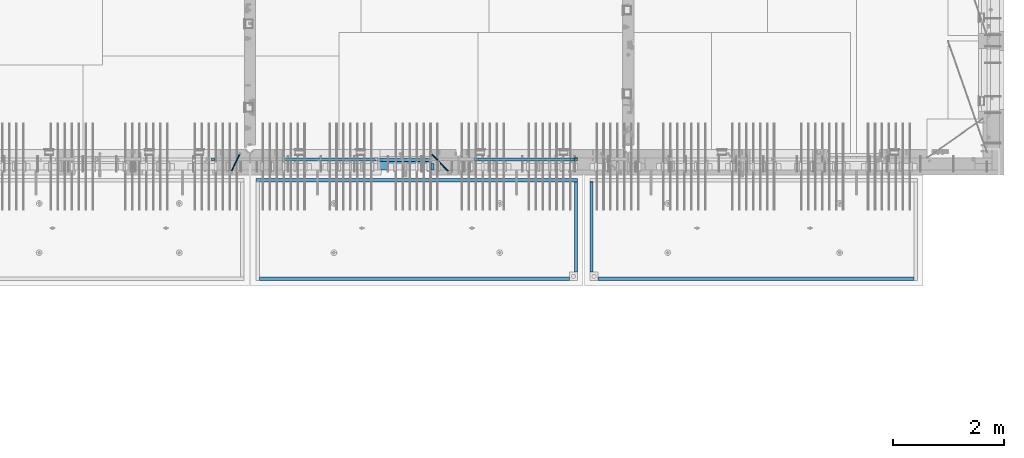
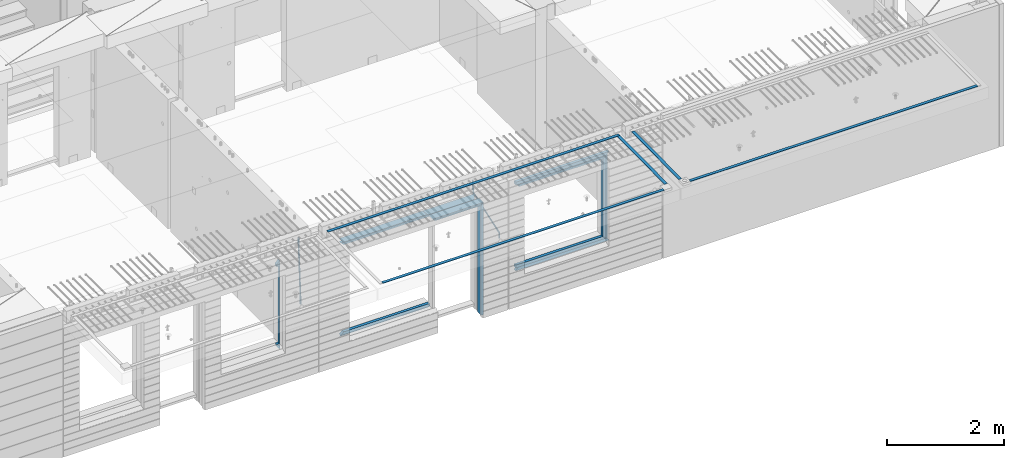
# One storey, part 91 of 334: 22 beams, 5 elements without a shape of their own.
"""IFC2X3 building model written with IfcOpenShell, lengths in millimetres."""

import ifcopenshell
import ifcopenshell.guid

model = None  # the IFC model being written
_history = None  # IfcOwnerHistory: only IFC2X3 demands one
_inside = {}  # id of a spatial element -> (the spatial element, [elements in it])
_under = {}  # id of a project, library or spatial element -> (it, [spatial elements below it])
_declared = {}  # id of a project -> (the project, [libraries it declares])
_typed = {}  # id of a type object -> (the type object, [elements of that type])
_made_of = {}  # id of a material, layer set ... -> (it, [elements and type objects made of it])


def new_model(schema):
    """Start an empty IFC model of exactly this schema.

    Asked for "IFC4X3", IfcOpenShell would pick the latest addendum, in which some entities
    have other attributes; the version numbers below select the first issue.
    IFC2X3 requires an IfcOwnerHistory on every rooted entity: one is made here for all.
    """
    global model, _history
    if schema == "IFC4X3":
        model = ifcopenshell.file(schema_version=(4, 3, 0, 0))
    else:
        model = ifcopenshell.file(schema=schema)
    _inside.clear()
    _under.clear()
    _declared.clear()
    _typed.clear()
    _made_of.clear()
    _history = None
    if model.schema == "IFC2X3":
        org = make("IfcOrganization", Name="unknown")
        user = make(
            "IfcPersonAndOrganization",
            ThePerson=make("IfcPerson", FamilyName="unknown"),
            TheOrganization=org,
        )
        app = make(
            "IfcApplication",
            ApplicationDeveloper=org,
            Version="unknown",
            ApplicationFullName="unknown",
            ApplicationIdentifier="unknown",
        )
        _history = make(
            "IfcOwnerHistory",
            OwningUser=user,
            OwningApplication=app,
            ChangeAction="ADDED",
            CreationDate=0,
        )
    return model


def make(cls, **values):
    """One entity of the class cls with the attributes given. An attribute that is None is left unset."""
    return model.create_entity(
        cls, **{name: value for name, value in values.items() if value is not None}
    )


def rooted(cls, **values):
    """An entity with a GlobalId (a new one), such as an element, a storey or a relation."""
    return make(cls, GlobalId=ifcopenshell.guid.new(), OwnerHistory=_history, **values)


def si_unit(unit_type, name, prefix=None):
    """IfcSIUnit, for example si_unit("LENGTHUNIT", "METRE", prefix="MILLI")."""
    return make("IfcSIUnit", UnitType=unit_type, Prefix=prefix, Name=name)


def assignment(units):
    """IfcUnitAssignment: the units of a project."""
    return None if units is None else make("IfcUnitAssignment", Units=units)


def point(xyz):
    """IfcCartesianPoint."""
    return None if xyz is None else make("IfcCartesianPoint", Coordinates=xyz)


def direction(xyz):
    """IfcDirection."""
    return None if xyz is None else make("IfcDirection", DirectionRatios=xyz)


def frame(location, z_axis=None, x_axis=None):
    """IfcAxis2Placement3D, a coordinate frame: its origin and axes. An axis left out is left unset."""
    return make(
        "IfcAxis2Placement3D",
        Location=point(location),
        Axis=direction(z_axis),
        RefDirection=direction(x_axis),
    )


def origin_with_axes():
    """The frame at (0, 0, 0) with the z axis (0, 0, 1) and the x axis (1, 0, 0) written out."""
    return frame((0.0, 0.0, 0.0), z_axis=(0.0, 0.0, 1.0), x_axis=(1.0, 0.0, 0.0))


def place(relative_to, where):
    """IfcLocalPlacement: puts the frame where relative to a parent placement (None: the world)."""
    return make(
        "IfcLocalPlacement", PlacementRelTo=relative_to, RelativePlacement=where
    )


def context(
    kind, dimensions, precision=None, world=None, true_north=None, identifier=None
):
    """IfcGeometricRepresentationContext, for example the 3D "Model" context."""
    return make(
        "IfcGeometricRepresentationContext",
        ContextIdentifier=identifier,
        ContextType=kind,
        CoordinateSpaceDimension=dimensions,
        Precision=precision,
        WorldCoordinateSystem=world,
        TrueNorth=true_north,
    )


def subcontext(parent, identifier, kind, view, scale=None):
    """IfcGeometricRepresentationSubContext, for example "Body" below "Model"."""
    return make(
        "IfcGeometricRepresentationSubContext",
        ContextIdentifier=identifier,
        ContextType=kind,
        ParentContext=parent,
        TargetScale=scale,
        TargetView=view,
    )


def project(units=None, contexts=None):
    """IfcProject with its units and contexts."""
    return rooted(
        "IfcProject",
        Name="project",
        RepresentationContexts=contexts,
        UnitsInContext=assignment(units),
    )


def spatial(cls, under=None, at=None, **own):
    """A site, building, storey or space (cls), placed at a placement, below another one or the project."""
    s = rooted(cls, ObjectPlacement=at, **own)
    if under is not None:
        _under.setdefault(under.id(), (under, []))[1].append(s)
    return s


def faces_of(points, faces, orient=None, outer=None):
    """IfcFace entities. A face is a list of loops; a loop is a list of indices into points, from 0.

    orient and outer hold one flag for each loop. By default every Orientation is true, the
    first loop of a face is its IfcFaceOuterBound and the others are IfcFaceBound.
    """
    made = []
    for i, loops in enumerate(faces):
        bounds = []
        for j, loop in enumerate(loops):
            is_outer = j == 0 if outer is None else outer[i][j]
            bounds.append(
                make(
                    "IfcFaceOuterBound" if is_outer else "IfcFaceBound",
                    Bound=make("IfcPolyLoop", Polygon=[points[k] for k in loop]),
                    Orientation=True if orient is None else orient[i][j],
                )
            )
        made.append(make("IfcFace", Bounds=bounds))
    return made


def faceted_brep(points, faces, orient=None, outer=None, voids=None):
    """IfcFacetedBrep: a solid bounded by flat faces; with voids (closed shells), ...WithVoids."""
    shared = [point(p) for p in points]
    hull = make("IfcClosedShell", CfsFaces=faces_of(shared, faces, orient, outer))
    if voids is None:
        return make("IfcFacetedBrep", Outer=hull)
    return make(
        "IfcFacetedBrepWithVoids",
        Outer=hull,
        Voids=[
            make(cls, CfsFaces=faces_of(shared, fs, o, b)) for cls, fs, o, b in voids
        ],
    )


def shape(context_of_items, identifier, shape_type, items):
    """IfcShapeRepresentation: the items that make up one representation, for example the "Body"."""
    return make(
        "IfcShapeRepresentation",
        ContextOfItems=context_of_items,
        RepresentationIdentifier=identifier,
        RepresentationType=shape_type,
        Items=items,
    )


def material(Name=None, Category=None):
    """IfcMaterial."""
    return make("IfcMaterial", Name=Name, Category=Category)


def made_of(thing, what):
    """Note that an element or type object is made of a material, layer set ...; save() writes the relation."""
    if what is not None:
        _made_of.setdefault(what.id(), (what, []))[1].append(thing)
    return thing


def type_object(cls, material=None, **own):
    """A type object (cls), such as IfcWallType, which elements share."""
    return made_of(rooted(cls, **own), material)


def element(
    cls,
    number,
    at=None,
    inside=None,
    cuts=None,
    type_object=None,
    material=None,
    context=None,
    identifier="Body",
    shape_type=None,
    held_by="IfcProductDefinitionShape",
    body=None,
    shapes=None,
    **own,
):
    """One element of the class cls, such as IfcWall. Its Tag is "e" and its number.

    at: its placement. inside: the storey or other place that contains it. cuts: it is an
    opening in that element (IfcRelVoidsElement). A single representation is given by context,
    identifier, shape_type and body (its items); several are given by shapes. held_by: the class
    of the entity that holds the representations. save() writes the other relations.
    """
    e = rooted(cls, Tag="e%d" % number, ObjectPlacement=at, **own)
    if body is not None:
        shapes = [shape(context, identifier, shape_type, body)]
    if shapes is not None:
        e.Representation = make(held_by, Representations=shapes)
    if inside is not None:
        _inside.setdefault(inside.id(), (inside, []))[1].append(e)
    if cuts is not None:
        rooted(
            "IfcRelVoidsElement", RelatingBuildingElement=cuts, RelatedOpeningElement=e
        )
    if type_object is not None:
        _typed.setdefault(type_object.id(), (type_object, []))[1].append(e)
    return made_of(e, material)


def aggregate(whole, parts):
    """IfcRelAggregates: a whole, such as a stair, and the parts it consists of."""
    return rooted("IfcRelAggregates", RelatingObject=whole, RelatedObjects=parts)


def save(model, path):
    """Write the relations noted so far, then the file.

    IfcRelAggregates (storeys below a building ...), IfcRelContainedInSpatialStructure (elements
    in a storey), IfcRelDefinesByType, IfcRelAssociatesMaterial and IfcRelDeclares: one each for
    every whole, place, type object, material and project.
    """
    for whole, parts in _under.values():
        aggregate(whole, parts)
    for where, things in _inside.values():
        rooted(
            "IfcRelContainedInSpatialStructure",
            RelatedElements=things,
            RelatingStructure=where,
        )
    for kind, things in _typed.values():
        rooted("IfcRelDefinesByType", RelatedObjects=things, RelatingType=kind)
    for what, things in _made_of.values():
        rooted("IfcRelAssociatesMaterial", RelatedObjects=things, RelatingMaterial=what)
    for by, libraries in _declared.values():
        rooted("IfcRelDeclares", RelatingContext=by, RelatedDefinitions=libraries)
    model.write(path)


model = new_model("IFC2X3")

# Units and contexts
model_context = context("Model", 3, precision=1e-05, world=origin_with_axes())
body_context = subcontext(model_context, "Body", "Model", "MODEL_VIEW")
ifc_project = project(units=[si_unit("LENGTHUNIT", "METRE", prefix="MILLI"), si_unit("AREAUNIT", "SQUARE_METRE"), si_unit("VOLUMEUNIT", "CUBIC_METRE"), si_unit("MASSUNIT", "GRAM", prefix="KILO"), si_unit("TIMEUNIT", "SECOND"), si_unit("PLANEANGLEUNIT", "RADIAN"), si_unit("SOLIDANGLEUNIT", "STERADIAN"), si_unit("THERMODYNAMICTEMPERATUREUNIT", "DEGREE_CELSIUS"), si_unit("LUMINOUSINTENSITYUNIT", "LUMEN")], contexts=[model_context])

# Site, building, storey
site_placement = place(None, origin_with_axes())
site = spatial("IfcSite", under=ifc_project, at=site_placement, CompositionType="ELEMENT")
building_placement = place(site_placement, origin_with_axes())
building = spatial("IfcBuilding", under=site, at=building_placement, CompositionType="ELEMENT")
storey_placement = place(building_placement, origin_with_axes())
storey = spatial("IfcBuildingStorey", under=building, at=storey_placement, Name="3", CompositionType="ELEMENT", Elevation=0.0)

# Assembly, beams
assembly_1_placement = place(storey_placement, origin_with_axes())
assembly_1 = element("IfcElementAssembly", 1, at=assembly_1_placement, inside=storey, AssemblyPlace="NOTDEFINED", PredefinedType="REINFORCEMENT_UNIT")
ifc_material_1 = material(Name="CONCRETE/C35/45")
beam_type_1 = type_object("IfcBeamType", PredefinedType="NOTDEFINED")
beam_1_placement = place(assembly_1_placement, frame((24034.9998642727, 7815.0, 90140.0), z_axis=(0.0, 0.0, -1.0), x_axis=(1.0, 0.0, 0.0)))
beam_1 = element("IfcBeam", 2, at=beam_1_placement, type_object=beam_type_1, material=ifc_material_1, Name="SK", context=body_context, shape_type="Brep", body=[
    faceted_brep([(70.0000000000164, -35.0, 35.0), (70.0000000000164, 35.0, 35.0), (0.0, -35.0, -35.0), (1039.99961853026, -35.0, -35.0), (980.889062997325, -35.0, 35.0), (980.889062997325, 35.0, 35.0)], [[[0, 1, 2]], [[0, 2, 3, 4]], [[1, 0, 4, 5]], [[2, 1, 5, 3]], [[4, 3, 5]]]),
])
ifc_material_2 = material(Name="TIMBER")
beam_type_2 = type_object("IfcBeamType", Name="50X150", PredefinedType="NOTDEFINED")
beam_2_placement = place(assembly_1_placement, frame((24104.9998642727, 7705.0, 90080.0), z_axis=(0.0, 0.0, -1.0), x_axis=(1.0, 0.0, 0.0)))
beam_2 = element("IfcBeam", 3, at=beam_2_placement, type_object=beam_type_2, material=ifc_material_2, ObjectType="50X150", context=body_context, shape_type="Brep", body=[
    faceted_brep([(50.0000000000036, -75.0, 25.0), (50.0000000000036, 75.0, 25.0), (0.0, 75.0, -25.0), (0.0, -75.0, -25.0), (1009.99961853027, -75.0, -25.0), (959.999618530259, -75.0, 25.0), (959.999618530259, 75.0, 25.0), (1009.99961853027, 75.0, -25.0)], [[[0, 1, 2, 3]], [[0, 3, 4, 5]], [[1, 0, 5, 6]], [[2, 1, 6, 7]], [[3, 2, 7, 4]], [[6, 5, 4, 7]]]),
])

# Assembly, beam
assembly_2_placement = place(storey_placement, origin_with_axes())
assembly_2 = element("IfcElementAssembly", 4, at=assembly_2_placement, inside=storey, AssemblyPlace="NOTDEFINED", PredefinedType="REINFORCEMENT_UNIT")
ifc_material_3 = material()
beam_type_3 = type_object("IfcBeamType", Name="D20", PredefinedType="NOTDEFINED")
beam_3_placement = place(assembly_2_placement, frame((21625.0073331492, 7924.99999997881, 90407.5), z_axis=(-0.000415599999849952, -0.999999913638316, 0.0), x_axis=(-6.05680000062309e-05, -4.00000390151988e-09, -0.999999998165759)))
beam_3 = element("IfcBeam", 5, at=beam_3_placement, type_object=beam_type_3, material=ifc_material_3, Name="JM20", ObjectType="D20", context=body_context, shape_type="Brep", body=[
    faceted_brep([(-0.00060564729210455, -9.99999998165731, 0.0), (-0.000428079845733009, -7.07106779890455, -7.07106781186667), (119.575515501536, -7.07830994756296, -7.07106481604933), (119.575337932896, -10.0072421307195, -3.43332612828817e-06), (0.0, 0.0, -10.0), (119.575943836026, -0.00724214867295814, -9.99999700418266), (0.00042843479604926, 7.07106779888636, -7.07106781186303), (119.57637202373, 7.06382565022977, -7.07106481604933), (0.00060564729210455, 9.99999998166459, 3.63797880709171e-12), (119.576549238118, 9.99275783300072, 2.99581552098971e-06), (0.000428079845733009, 7.07106779890819, 7.07106781186667), (119.576371669405, 7.06382565024978, 7.07107080768037), (0.0, 0.0, 10.0), (119.57594333493, -0.00724214864203532, 10.0000029958155), (-0.000428434810601175, -7.07106779888272, 7.07106781186667), (119.575515147211, -7.07830994754295, 7.07107080768037), (123.006973508192, -7.07825951346604, -6.96785036235087), (122.582196132164, -10.0072047447829, 0.090452766209637), (123.182421564867, -0.00718632049392909, -9.89150999405319), (123.005765870272, 7.06387605862983, -6.9678969281922), (122.5804889344, 9.99279518261392, 0.090375952400791), (122.155712218591, 7.06384995171538, 7.14866812117907), (121.980264161975, -0.00722324126036256, 10.0723277528814), (122.156919856599, -7.07828562038412, 7.14871468701676), (235.904703171851, -7.06860422895625, -0.169508357435916), (235.479926262604, -9.99754169577864, 6.88878701985595), (236.080151695453, 0.002465748351824, -3.09317573838871), (235.903496467319, 7.07353134315781, -0.16957042179456), (235.478219724217, 10.0024582304504, 6.88869924890878), (235.053442814489, 7.07352076285679, 13.9469946275131), (234.877994290917, 0.00245078554871725, 16.8706620084649), (235.05464951905, -7.06861480925727, 13.9470566918726), (247.69730842374, 6.49890140729985, 1.5904257279044), (247.708271375333, -0.564091162203113, -1.35790592567901), (246.351191555892, -7.5775885142175, 1.3894260566567), (244.421027918448, -10.4331790195793, 8.22307186000126), (243.04844414418, -7.45809648886643, 15.1399744532118), (243.037481192529, -0.395103919359826, 18.0883061067871), (244.394561011999, 6.61839343264, 15.3409741244495), (246.324724649443, 9.47398393802723, 8.50732832109588), (256.620302657771, 7.90789673379186, 11.9850227549905), (258.892076862918, 4.79603600307382, 5.371853429986), (253.26121545503, 5.26966351612282, 18.3359992487194), (250.782522980895, -1.57322241172369, 20.7044670154446), (250.636209669712, -8.61229127897968, 17.7030097594688), (252.907983874131, -11.724152010418, 11.0898404357176), (256.267071077629, -9.08591879203959, 4.7388639407518), (258.745763551793, -2.24303286420036, 2.37039617402661), (1008.47908473376, -166.485147783689, 337.205828025195), (1005.11999753102, -169.123381001344, 343.556804518913), (1010.95777720789, -159.642261855857, 334.837360258474), (1011.10409051905, -152.60319298859, 337.838817514449), (1008.83231631388, -149.491332257865, 344.451986839456), (1005.47322911114, -152.129565475519, 350.802963333173), (1002.99453663701, -158.972451403351, 353.171431099895), (1002.84822332587, -166.011520270618, 350.169973843918), (1010.17087503639, -166.839152352099, 337.953575170377), (1008.40147312843, -169.810024819315, 345.007169854448), (1011.47638800017, -159.75078038171, 335.066578819891), (1011.55326023143, -152.697181073247, 338.037344110582), (1010.35646101969, -149.810257238067, 345.125637025791), (1008.58705911171, -152.781129705283, 352.179231709861), (1007.28154614793, -159.869501675676, 355.066228060347), (1007.20467391667, -166.923100984135, 352.095462769656), (1012.05411677422, -166.839038287919, 337.953575122971), (1012.05429688386, -169.809803575103, 345.007169762499), (1012.05368737834, -159.750745415844, 335.066578805359), (1012.05326023052, -152.697150789249, 338.037344097996), (1012.05308554815, -149.81015447692, 345.125636983083), (1012.05326565779, -152.780919764096, 352.179231622609), (1012.05369505366, -159.869212636178, 355.066227940223), (1012.05412220149, -166.92280726277, 352.095462647586), (1117.510115663, -166.832651029355, 337.953572468433), (1117.51029577265, -169.803416316539, 345.00716710796), (1117.50968626713, -159.744358157277, 335.06657615082), (1117.50925911931, -152.690763530685, 338.037341443456), (1117.50908443694, -149.803767218353, 345.125634328543), (1117.50926454658, -152.774532505533, 352.17922896807), (1117.50969394245, -159.862825377615, 355.066225285684), (1117.51012109026, -166.916420004207, 352.095459993046)], [[[0, 1, 2, 3]], [[1, 4, 5, 2]], [[4, 6, 7, 5]], [[6, 8, 9, 7]], [[8, 10, 11, 9]], [[10, 12, 13, 11]], [[12, 14, 15, 13]], [[14, 0, 3, 15]], [[14, 12, 10, 8, 6, 4, 1, 0]], [[3, 2, 16, 17]], [[2, 5, 18, 16]], [[5, 7, 19, 18]], [[7, 9, 20, 19]], [[9, 11, 21, 20]], [[11, 13, 22, 21]], [[13, 15, 23, 22]], [[15, 3, 17, 23]], [[17, 16, 24, 25]], [[16, 18, 26, 24]], [[18, 19, 27, 26]], [[19, 20, 28, 27]], [[20, 21, 29, 28]], [[21, 22, 30, 29]], [[22, 23, 31, 30]], [[23, 17, 25, 31]], [[26, 27, 32, 33]], [[24, 26, 33, 34]], [[25, 24, 34, 35]], [[31, 25, 35, 36]], [[30, 31, 36, 37]], [[29, 30, 37, 38]], [[28, 29, 38, 39]], [[27, 28, 39, 32]], [[39, 40, 41, 32]], [[38, 42, 40, 39]], [[37, 43, 42, 38]], [[36, 44, 43, 37]], [[35, 45, 44, 36]], [[34, 46, 45, 35]], [[33, 47, 46, 34]], [[32, 41, 47, 33]], [[45, 46, 48, 49]], [[46, 47, 50, 48]], [[47, 41, 51, 50]], [[41, 40, 52, 51]], [[40, 42, 53, 52]], [[42, 43, 54, 53]], [[43, 44, 55, 54]], [[44, 45, 49, 55]], [[49, 48, 56, 57]], [[48, 50, 58, 56]], [[50, 51, 59, 58]], [[51, 52, 60, 59]], [[52, 53, 61, 60]], [[53, 54, 62, 61]], [[54, 55, 63, 62]], [[55, 49, 57, 63]], [[57, 56, 64, 65]], [[56, 58, 66, 64]], [[58, 59, 67, 66]], [[59, 60, 68, 67]], [[60, 61, 69, 68]], [[61, 62, 70, 69]], [[62, 63, 71, 70]], [[63, 57, 65, 71]], [[65, 64, 72, 73]], [[64, 66, 74, 72]], [[66, 67, 75, 74]], [[67, 68, 76, 75]], [[68, 69, 77, 76]], [[69, 70, 78, 77]], [[70, 71, 79, 78]], [[71, 65, 73, 79]], [[74, 75, 76, 77, 78, 79, 73, 72]]]),
])

# Beam
beam_4_placement = place(assembly_1_placement, frame((25075.0293329014, 7924.99999993642, 90407.5), z_axis=(-0.000415599999849952, -0.999999913638316, 0.0), x_axis=(-0.000242263999929879, 0.0, -0.999999970654077)))
beam_4 = element("IfcBeam", 6, at=beam_4_placement, type_object=beam_type_3, material=ifc_material_3, Name="JM20", ObjectType="D20", context=body_context, shape_type="Brep", body=[
    faceted_brep([(-0.00060564729210455, -9.99999998165731, 0.0), (-0.000428079845733009, -7.07106779890455, -7.07106781186667), (119.575515501536, -7.07830994756296, -7.07106481604933), (119.575337932896, -10.0072421307195, -3.43332612828817e-06), (0.0, 0.0, -10.0), (119.575943836026, -0.00724214867295814, -9.99999700418266), (0.00042843479604926, 7.07106779888636, -7.07106781186303), (119.57637202373, 7.06382565022977, -7.07106481604933), (0.00060564729210455, 9.99999998166459, 3.63797880709171e-12), (119.576549238118, 9.99275783300072, 2.99581552098971e-06), (0.000428079845733009, 7.07106779890819, 7.07106781186667), (119.576371669405, 7.06382565024978, 7.07107080768037), (0.0, 0.0, 10.0), (119.57594333493, -0.00724214864203532, 10.0000029958155), (-0.000428434810601175, -7.07106779888272, 7.07106781186667), (119.575515147211, -7.07830994754295, 7.07107080768037), (123.008274907785, -7.07795567963694, -6.96780325792497), (122.584029738471, -10.0069316327917, 0.0905081323508057), (123.182440752484, -0.00686994861462153, -9.89150922917906), (123.004503280346, 7.06417944043824, -6.96794247666548), (122.578695849254, 9.99306765562687, 0.0903112464729929), (122.15445067735, 7.0640917031651, 7.14862263591931), (121.980284832651, -0.0069940278553986, 10.072328607177), (122.158222304832, -7.07804341691372, 7.14876185467801), (233.088395941915, -7.04853267872386, -0.33914435535371), (232.664150764584, -9.97750862893736, 6.71916703474017), (233.262561786629, 0.0225530520438042, -3.26285032724809), (233.08462431423, 7.09360244138225, -0.339283575355694), (232.658816882788, 10.0224906572403, 6.71897014756632), (232.234571710651, 7.09351470543697, 13.777281537301), (232.060405865923, 0.0224289746693103, 16.7009875091953), (232.238343338337, -7.04862041468004, 13.7774207573038), (248.070459246126, -5.60737147376494, 1.85103242021069), (247.013897852143, -8.59717146491312, 8.81690765643543), (244.865343898215, -5.8339984379636, 15.6233189364948), (242.883391151001, 1.06351832306973, 18.2831628436061), (242.22904064988, 8.05490704629119, 15.2383388907911), (243.285602043848, 11.0447070374539, 8.27246365456904), (245.434155997835, 8.28153401051895, 1.46605237452331), (247.416108745019, 1.38401724946743, -1.19379153259433), (260.512945877912, 5.37327174938764, 3.16696371259513), (261.933955342625, -1.38459511741894, 6.46705632785779), (256.86166640259, 11.762316953962, 5.27098446848322), (253.118986913221, 14.0399244660766, 11.5466117722399), (251.477318295016, 10.8719026949148, 18.3176682617204), (252.898327759729, 4.11403582813364, 21.6177608769931), (256.54960723508, -2.27500937642981, 19.5137401211105), (260.292286730517, -4.55261688891915, 13.2381128181169), (1011.6899267952, 318.016952836686, 337.688913324002), (1010.04825817693, 314.848931065488, 344.459969813425), (1010.26891733034, 324.774819703332, 334.388820708672), (1006.61763785462, 331.163864907652, 336.492841464405), (1002.87495836492, 333.441472419578, 342.76846876801), (1001.23328974665, 330.273450648383, 349.539525257433), (1002.6542992115, 323.515583781733, 352.839617872763), (1006.30557868723, 317.12653857741, 350.73559711703), (1012.11607330808, 318.198494379605, 337.877173297548), (1011.23010097447, 315.352404773395, 344.982075913254), (1011.34812648257, 325.234570724882, 334.865586047124), (1009.37611333313, 332.338995712049, 337.711461129013), (1007.35521241752, 335.350093536494, 344.747723517063), (1006.46924008391, 332.504003930284, 351.85262613277), (1007.23718690944, 325.467927585003, 354.864213383194), (1009.20920005886, 318.363502597836, 352.018338301305), (1012.61607329341, 318.198615511596, 337.877173247205), (1012.61676345688, 315.352740711776, 344.982075773638), (1012.61436835937, 325.234877489685, 334.865585919631), (1012.61264738202, 332.339779807688, 337.71146080314), (1012.61191848651, 335.351367047057, 344.747722987787), (1012.61260864999, 332.505492247237, 351.852625514221), (1012.61431358402, 325.469230269144, 354.864212841793), (1012.61603456138, 318.364327951142, 352.018337958285), (1117.42297412557, 318.224006449098, 337.87716269464), (1117.42366428903, 315.378131649279, 344.982065221072), (1117.42126919153, 325.260268427191, 334.865575367066), (1117.41954821418, 332.365170745194, 337.711450250575), (1117.41881931867, 335.376757984559, 344.747712435222), (1117.41950948215, 332.530883184736, 351.852614961655), (1117.42121441617, 325.494621206646, 354.864202289227), (1117.42293539354, 318.389718888644, 352.018327405719)], [[[0, 1, 2, 3]], [[1, 4, 5, 2]], [[4, 6, 7, 5]], [[6, 8, 9, 7]], [[8, 10, 11, 9]], [[10, 12, 13, 11]], [[12, 14, 15, 13]], [[14, 0, 3, 15]], [[14, 12, 10, 8, 6, 4, 1, 0]], [[3, 2, 16, 17]], [[2, 5, 18, 16]], [[5, 7, 19, 18]], [[7, 9, 20, 19]], [[9, 11, 21, 20]], [[11, 13, 22, 21]], [[13, 15, 23, 22]], [[15, 3, 17, 23]], [[17, 16, 24, 25]], [[16, 18, 26, 24]], [[18, 19, 27, 26]], [[19, 20, 28, 27]], [[20, 21, 29, 28]], [[21, 22, 30, 29]], [[22, 23, 31, 30]], [[23, 17, 25, 31]], [[25, 24, 32, 33]], [[31, 25, 33, 34]], [[30, 31, 34, 35]], [[29, 30, 35, 36]], [[28, 29, 36, 37]], [[27, 28, 37, 38]], [[26, 27, 38, 39]], [[24, 26, 39, 32]], [[39, 40, 41, 32]], [[38, 42, 40, 39]], [[37, 43, 42, 38]], [[36, 44, 43, 37]], [[35, 45, 44, 36]], [[34, 46, 45, 35]], [[33, 47, 46, 34]], [[32, 41, 47, 33]], [[47, 41, 48, 49]], [[41, 40, 50, 48]], [[40, 42, 51, 50]], [[42, 43, 52, 51]], [[43, 44, 53, 52]], [[44, 45, 54, 53]], [[45, 46, 55, 54]], [[46, 47, 49, 55]], [[49, 48, 56, 57]], [[48, 50, 58, 56]], [[50, 51, 59, 58]], [[51, 52, 60, 59]], [[52, 53, 61, 60]], [[53, 54, 62, 61]], [[54, 55, 63, 62]], [[55, 49, 57, 63]], [[57, 56, 64, 65]], [[56, 58, 66, 64]], [[58, 59, 67, 66]], [[59, 60, 68, 67]], [[60, 61, 69, 68]], [[61, 62, 70, 69]], [[62, 63, 71, 70]], [[63, 57, 65, 71]], [[65, 64, 72, 73]], [[64, 66, 74, 72]], [[66, 67, 75, 74]], [[67, 68, 76, 75]], [[68, 69, 77, 76]], [[69, 70, 78, 77]], [[70, 71, 79, 78]], [[71, 65, 73, 79]], [[74, 75, 76, 77, 78, 79, 73, 72]]]),
])

# Assembly, beams
assembly_3_placement = place(storey_placement, origin_with_axes())
assembly_3 = element("IfcElementAssembly", 7, at=assembly_3_placement, inside=storey, AssemblyPlace="NOTDEFINED", PredefinedType="REINFORCEMENT_UNIT")
ifc_material_4 = material(Name="CONCRETE/Concrete_Undefined")
beam_type_4 = type_object("IfcBeamType", PredefinedType="NOTDEFINED")
beam_5_placement = place(assembly_3_placement, frame((27949.9413896323, 7420.0548526853, 90725.6636564041), z_axis=(3.20999999465459e-07, -0.00901957599816896, 0.999959322797038), x_axis=(3.55380000057318e-05, -0.999959322165559, -0.00901957600149657)))
beam_5 = element("IfcBeam", 8, at=beam_5_placement, type_object=beam_type_4, material=ifc_material_4, context=body_context, shape_type="Brep", body=[
    faceted_brep([(2.5465851649642e-11, 29.9999999999982, -4.99999999998545), (-2.91038304567337e-11, 29.9999999999982, 5.0), (1625.35189228369, 30.0000000000073, 5.0), (1625.35189228371, 30.0000000000073, -5.0), (-2.5465851649642e-11, -30.0000000000018, 5.0), (1625.35189228368, -29.9999999999927, 5.00000000001455), (2.72848410531878e-11, -30.0000000000018, -4.99999999998545), (1625.35189228371, -29.9999999999927, -4.99999999998545)], [[[0, 1, 2, 3]], [[1, 4, 5, 2]], [[4, 6, 7, 5]], [[6, 0, 3, 7]], [[5, 7, 3, 2]], [[6, 4, 1, 0]]]),
])
beam_6_placement = place(assembly_3_placement, frame((33750.1798578673, 5674.89208457699, 90711.2777998596), z_axis=(-0.00010875600001081, -1.00000033862182e-09, 0.999999994086066), x_axis=(-0.999999994070015, -5.66600000038745e-06, -0.000108756000006807)))
beam_6 = element("IfcBeam", 9, at=beam_6_placement, type_object=beam_type_4, material=ifc_material_4, context=body_context, shape_type="Brep", body=[
    faceted_brep([(2.5465851649642e-11, 29.9999999999982, -4.99999999998545), (-2.91038304567337e-11, 29.9999999999982, 5.0), (5682.56261276337, 30.0, 5.0), (5682.56261276337, 30.0, -5.0), (-2.5465851649642e-11, -30.0000000000018, 5.0), (5682.56261276337, -30.0, 5.0), (2.72848410531878e-11, -30.0000000000018, -4.99999999998545), (5682.56261276337, -30.0, -5.0)], [[[0, 1, 2, 3]], [[1, 4, 5, 2]], [[4, 6, 7, 5]], [[6, 0, 3, 7]], [[5, 7, 3, 2]], [[6, 4, 1, 0]]]),
])
aggregate(assembly_3, [beam_5, beam_6])

assembly_4_placement = place(storey_placement, origin_with_axes())
assembly_4 = element("IfcElementAssembly", 10, at=assembly_4_placement, inside=storey, AssemblyPlace="NOTDEFINED", PredefinedType="REINFORCEMENT_UNIT")
beam_7_placement = place(assembly_4_placement, frame((27670.0013901304, 7419.94686420498, 90725.2791047129), z_axis=(-7.99999906695021e-09, -0.0106298469955396, 0.99994350158039), x_axis=(-7.67999998664137e-07, -0.999943501580095, -0.0106298469955353)))
beam_7 = element("IfcBeam", 11, at=beam_7_placement, type_object=beam_type_4, material=ifc_material_4, context=body_context, shape_type="Brep", body=[
    faceted_brep([(2.5465851649642e-11, 29.9999999999982, -4.99999999998545), (-2.91038304567337e-11, 29.9999999999982, 5.0), (1625.17584384035, 29.9999999999964, 5.0), (1625.17584384035, 30.0000000000036, -4.99999999998545), (-2.5465851649642e-11, -30.0000000000018, 5.0), (1625.17584384035, -30.0, 5.0), (2.72848410531878e-11, -30.0000000000018, -4.99999999998545), (1625.17584384035, -29.9999999999964, -4.99999999998545)], [[[0, 1, 2, 3]], [[1, 4, 5, 2]], [[4, 6, 7, 5]], [[6, 0, 3, 7]], [[5, 7, 3, 2]], [[6, 4, 1, 0]]]),
])
beam_8_placement = place(assembly_4_placement, frame((27700.0033616247, 7449.93184428144, 90725.2788442816), z_axis=(6.6541999986247e-05, -1.00000033832184e-09, 0.999999997786081), x_axis=(-0.999999997707994, 1.24969999963762e-05, 6.65419999798477e-05)))
beam_8 = element("IfcBeam", 12, at=beam_8_placement, type_object=beam_type_4, material=ifc_material_4, context=body_context, shape_type="Brep", body=[
    faceted_brep([(2.5465851649642e-11, 29.9999999999982, -4.99999999998545), (-2.91038304567337e-11, 29.9999999999982, 5.0), (5780.0600107005, 30.0, 5.00000000001455), (5780.0600107005, 30.0000000000009, -5.0), (-2.5465851649642e-11, -30.0000000000018, 5.0), (5780.0600107005, -30.0000000000009, 5.00000000001455), (2.72848410531878e-11, -30.0000000000018, -4.99999999998545), (5780.0600107005, -30.0, -4.99999999998545)], [[[0, 1, 2, 3]], [[1, 4, 5, 2]], [[4, 6, 7, 5]], [[6, 0, 3, 7]], [[5, 7, 3, 2]], [[6, 4, 1, 0]]]),
])
beam_9_placement = place(assembly_4_placement, frame((21979.9397016438, 5674.8679591, 90709.8457712343), z_axis=(0.000327872000083623, 1.99999976807677e-09, 0.999999946249974), x_axis=(0.999999946233322, 5.77100000136594e-06, -0.000327872000077393)))
beam_9 = element("IfcBeam", 13, at=beam_9_placement, type_object=beam_type_4, material=ifc_material_4, context=body_context, shape_type="Brep", body=[
    faceted_brep([(2.5465851649642e-11, 29.9999999999982, -4.99999999998545), (-2.91038304567337e-11, 29.9999999999982, 5.0), (5570.052902922, 30.0000000000009, 5.00000000001455), (5570.05290292199, 30.0000000000009, -4.99999999998545), (-2.5465851649642e-11, -30.0000000000018, 5.0), (5570.052902922, -30.0, 5.00000000001455), (2.72848410531878e-11, -30.0000000000018, -4.99999999998545), (5570.05290292199, -30.0, -4.99999999998545)], [[[0, 1, 2, 3]], [[1, 4, 5, 2]], [[4, 6, 7, 5]], [[6, 0, 3, 7]], [[5, 7, 3, 2]], [[6, 4, 1, 0]]]),
])
aggregate(assembly_4, [beam_7, beam_8, beam_9])

# Beam
beam_type_5 = type_object("IfcBeamType", PredefinedType="NOTDEFINED")
beam_10_placement = place(assembly_2_placement, frame((21144.9998642727, 7820.0, 90175.0), z_axis=(-1.0, 3.00000001838171e-08, 0.0), x_axis=(0.0, 0.0, -1.0)))
beam_10 = element("IfcBeam", 14, at=beam_10_placement, type_object=beam_type_5, material=ifc_material_1, Name="SK", context=body_context, shape_type="Brep", body=[
    faceted_brep([(1740.94594594595, -30.0, 30.0), (1739.32432432432, 30.0, 30.0), (1739.32432432432, 30.0, -24.3243243243269), (1740.94594594595, -30.0, -25.9459459459504), (115.67567567568, 30.0, -24.3243243243269), (114.054054054053, -30.0, -25.9459459459504), (115.67567567568, 30.0, 30.0), (114.054054054053, -30.0, 30.0), (72.2635272671032, 30.0, 30.0), (72.2635272671032, -30.0, 30.0), (0.0, 30.0, -30.0), (0.0, -30.0, -30.0), (1855.0, -30.0, -30.0), (1782.73647273288, -30.0, 30.0), (1782.73647273287, 30.0, 30.0), (1855.0, 30.0, -30.0)], [[[0, 1, 2, 3]], [[3, 2, 4, 5]], [[5, 4, 6, 7]], [[7, 6, 8, 9]], [[10, 11, 9, 8]], [[0, 3, 5, 7, 9, 11, 12, 13]], [[1, 0, 13, 14]], [[10, 8, 6, 4, 2, 1, 14, 15]], [[15, 12, 11, 10]], [[15, 14, 13, 12]]]),
])

beam_11_placement = place(assembly_1_placement, frame((22384.9998642751, 7820.0, 90145.0), z_axis=(0.0, 0.0, -1.0), x_axis=(1.0, 0.0, 0.0)))
beam_11 = element("IfcBeam", 15, at=beam_11_placement, type_object=beam_type_5, material=ifc_material_1, Name="SK", context=body_context, shape_type="Brep", body=[
    faceted_brep([(1820.00000000026, -30.0, 30.0), (1820.00000000026, -30.0, -30.0), (1820.00000000026, 30.0, 30.0), (49.817662327685, -30.0, 30.0), (0.0, -30.0, -30.0), (49.817662327685, 30.0, 30.0)], [[[0, 1, 2]], [[1, 0, 3, 4]], [[2, 1, 4, 5]], [[0, 2, 5, 3]], [[4, 3, 5]]]),
])

beam_12_placement = place(assembly_1_placement, frame((22384.9998642751, 7820.0, 90085.0), z_axis=(0.0, 0.0, -1.0), x_axis=(1.0, 0.0, 0.0)))
beam_12 = element("IfcBeam", 16, at=beam_12_placement, type_object=beam_type_5, material=ifc_material_1, Name="SK", context=body_context, shape_type="Brep", body=[
    faceted_brep([(1820.00000000026, -30.0, -30.0), (1820.00000000026, 30.0, -30.0), (1820.00000000026, 30.0, 25.6756756756804), (1820.00000000026, -30.0, 24.0540540540678), (59.8219112435072, 30.0, 25.6756756756804), (58.0795254791192, -30.0, 24.0540540540533), (0.0, -30.0, -30.0), (0.0, 30.0, -30.0)], [[[0, 1, 2, 3]], [[3, 2, 4, 5]], [[0, 3, 5, 6]], [[6, 7, 1, 0]], [[2, 1, 7, 4]], [[4, 7, 6, 5]]]),
])

beam_13_placement = place(assembly_1_placement, frame((24144.9998642753, 7820.0, 88150.0), z_axis=(0.0, 0.0, 1.0), x_axis=(-1.0, 3.00000001838171e-08, 0.0)))
beam_13 = element("IfcBeam", 17, at=beam_13_placement, type_object=beam_type_5, material=ifc_material_1, Name="SK", context=body_context, shape_type="Brep", body=[
    faceted_brep([(0.0, -30.0, 30.0), (-5.28234522789717e-09, 30.0, 30.0), (0.0, -30.0, -30.0), (1710.18233767259, -30.0, 30.0), (1710.18233767259, 30.0, 30.0), (1760.00000000026, -30.0, -30.0)], [[[0, 1, 2]], [[1, 0, 3, 4]], [[2, 1, 4, 5]], [[0, 2, 5, 3]], [[4, 3, 5]]]),
])

beam_14_placement = place(assembly_1_placement, frame((24144.9998642753, 7820.0, 88210.0), z_axis=(0.0, 0.0, 1.0), x_axis=(-1.0, 3.00000001838171e-08, 0.0)))
beam_14 = element("IfcBeam", 18, at=beam_14_placement, type_object=beam_type_5, material=ifc_material_1, Name="SK", context=body_context, shape_type="Brep", body=[
    faceted_brep([(0.0, 30.0, -30.0), (0.0, -30.0, -30.0), (0.0, -30.0, 24.0540540540678), (0.0, 30.0, 25.6756756756804), (1700.17808875675, 30.0, 25.6756756756804), (1760.00000000026, 30.0, -30.0), (1760.00000000026, -30.0, -30.0), (1701.92047452114, -30.0, 24.0540540540533)], [[[0, 1, 2, 3]], [[0, 3, 4, 5]], [[1, 0, 5, 6]], [[2, 1, 6, 7]], [[3, 2, 7, 4]], [[6, 5, 4, 7]]]),
])

# Assembly, beams
assembly_5_placement = place(storey_placement, origin_with_axes())
assembly_5 = element("IfcElementAssembly", 19, at=assembly_5_placement, inside=storey, AssemblyPlace="NOTDEFINED", PredefinedType="REINFORCEMENT_UNIT")
beam_15_placement = place(assembly_5_placement, frame((25845.0006272121, 7820.0, 90145.0), z_axis=(0.0, 0.0, -1.0), x_axis=(1.0, 0.0, 0.0)))
beam_15 = element("IfcBeam", 20, at=beam_15_placement, type_object=beam_type_5, material=ifc_material_1, Name="SK", context=body_context, shape_type="Brep", body=[
    faceted_brep([(0.0, -30.0, -30.0), (0.0, -30.0, 30.0), (-5.28234522789717e-09, 30.0, 30.0), (0.0, 30.0, -30.0), (1849.99885559082, -30.0, -30.0), (1789.99885559081, -30.0, 30.0), (1789.99885559081, 30.0, 30.0), (1849.99885559082, 30.0, -30.0)], [[[0, 1, 2, 3]], [[1, 0, 4, 5]], [[2, 1, 5, 6]], [[3, 2, 6, 7]], [[0, 3, 7, 4]], [[6, 5, 4, 7]]]),
])
beam_16_placement = place(assembly_5_placement, frame((25905.0006272121, 7820.0, 90085.0), z_axis=(0.0, 0.0, -1.0), x_axis=(1.0, 0.0, 0.0)))
beam_16 = element("IfcBeam", 21, at=beam_16_placement, type_object=beam_type_5, material=ifc_material_1, Name="SK", context=body_context, shape_type="Brep", body=[
    faceted_brep([(1665.94480153677, -30.0, 24.0540540540533), (1664.32317991515, 30.0, 25.6756756756804), (0.0, 30.0, 25.6756756756804), (0.0, -30.0, 24.0540540540678), (0.0, 30.0, -30.0), (0.0, -30.0, -30.0), (1729.99885559082, -30.0, -30.0), (1665.94480153677, -30.0, 24.9034748914419), (1664.32317991515, 30.0, 26.293436281092), (1729.99885559082, 30.0, -30.0)], [[[0, 1, 2, 3]], [[4, 5, 3, 2]], [[0, 3, 5, 6, 7]], [[1, 0, 7, 8]], [[4, 2, 1, 8, 9]], [[5, 4, 9, 6]], [[8, 7, 6, 9]]]),
])
beam_17_placement = place(assembly_5_placement, frame((27664.9994828029, 7820.0, 90175.0), z_axis=(-1.0, 3.00000001838171e-08, 0.0), x_axis=(0.0, 0.0, -1.0)))
beam_17 = element("IfcBeam", 22, at=beam_17_placement, type_object=beam_type_5, material=ifc_material_1, Name="SK", context=body_context, shape_type="Brep", body=[
    faceted_brep([(60.0000000000073, 30.0, 30.0), (0.0, -30.0, -30.0), (60.0000000000073, -30.0, 30.0), (1855.0, -30.0, -30.0), (1795.00000000001, -30.0, 30.0), (1795.00000000001, 30.0, 30.0)], [[[0, 1, 2]], [[3, 4, 2, 1]], [[4, 5, 0, 2]], [[5, 3, 1, 0]], [[4, 3, 5]]]),
])
beam_18_placement = place(assembly_5_placement, frame((27694.9994828029, 7820.0, 88350.0), z_axis=(0.0, 0.0, 1.0), x_axis=(-1.0, 3.00000001838171e-08, 0.0)))
beam_18 = element("IfcBeam", 23, at=beam_18_placement, type_object=beam_type_5, material=ifc_material_1, Name="SK", context=body_context, shape_type="Brep", body=[
    faceted_brep([(1849.99885559082, 30.0, -30.0), (1800.18119326315, 30.0, 30.0), (1800.18119326315, -30.0, 30.0), (1849.99885559082, -30.0, -30.0), (0.0, -30.0, -30.0), (0.0, 30.0, -30.0), (60.0000000000073, 30.0, 30.0), (60.0000000000073, -30.0, 30.0)], [[[0, 1, 2, 3]], [[4, 5, 0, 3]], [[1, 0, 5, 6]], [[2, 1, 6, 7]], [[3, 2, 7, 4]], [[6, 5, 4, 7]]]),
])
beam_19_placement = place(assembly_5_placement, frame((27634.9994828029, 7820.0, 88410.0), z_axis=(0.0, 0.0, 1.0), x_axis=(-1.0, 3.00000001838171e-08, 0.0)))
beam_19 = element("IfcBeam", 24, at=beam_19_placement, type_object=beam_type_5, material=ifc_material_1, Name="SK", context=body_context, shape_type="Brep", body=[
    faceted_brep([(1785.94885559082, 30.0, 30.0), (1784.32432432432, 30.0, 30.0), (1785.94885559082, -30.0, 30.0), (1785.94885559082, -30.0, 24.0540519302303), (1784.32432432433, 30.0, 25.6756756756804), (65.6756756756768, 30.0, 25.6756756756804), (64.0540540540533, -30.0, 24.0540540540533), (1785.94885559082, -30.0, -30.0), (1785.94885559082, 30.0, -30.0), (0.0, -30.0, -30.0), (0.0, 30.0, -30.0), (65.6756756756768, 30.0, 26.293436281092), (64.0540540540533, -30.0, 24.9034748914419)], [[[0, 1, 2]], [[3, 4, 5, 6]], [[1, 4, 3, 2]], [[7, 8, 0, 2, 3]], [[8, 7, 9, 10]], [[5, 4, 1, 0, 8, 10, 11]], [[6, 5, 11, 12]], [[7, 3, 6, 12, 9]], [[9, 12, 11, 10]]]),
])

# Beam
beam_type_6 = type_object("IfcBeamType", PredefinedType="NOTDEFINED")
beam_20_placement = place(assembly_2_placement, frame((21139.9998642727, 7820.0, 90115.0), z_axis=(-1.0, 3.00000001838171e-08, 0.0), x_axis=(0.0, 0.0, -1.0)))
beam_20 = element("IfcBeam", 25, at=beam_20_placement, type_object=beam_type_6, material=ifc_material_1, Name="SK", context=body_context, shape_type="Brep", body=[
    faceted_brep([(1680.94594594595, -30.0, -30.9459459459504), (1679.32432432432, 30.0, -29.3243243243269), (55.6756756756804, 30.0, -29.3243243243269), (54.0540540540533, -30.0, -30.9459459459504), (55.6756756756804, 30.0, 24.8219112435145), (54.0540540540533, -30.0, 23.0795254791374), (0.0, 30.0, -35.0), (0.0, -30.0, -35.0), (1735.0, -30.0, -35.0), (1680.94594594595, -30.0, 23.0795254791337), (1679.32432432432, 30.0, 24.8219112435145), (1735.0, 30.0, -35.0)], [[[0, 1, 2, 3]], [[3, 2, 4, 5]], [[4, 6, 7, 5]], [[0, 3, 5, 7, 8, 9]], [[1, 0, 9, 10]], [[6, 4, 2, 1, 10, 11]], [[11, 8, 7, 6]], [[10, 9, 8, 11]]]),
])

aggregate(assembly_2, [beam_3, beam_10, beam_20])

beam_21_placement = place(assembly_5_placement, frame((27599.9994828029, 7820.0, 90115.0), z_axis=(-1.0, 3.00000001838171e-08, 0.0), x_axis=(0.0, 0.0, -1.0)))
beam_21 = element("IfcBeam", 26, at=beam_21_placement, type_object=beam_type_6, material=ifc_material_1, Name="SK", context=body_context, shape_type="Brep", body=[
    faceted_brep([(0.0, -30.0, -35.0), (54.9034748914273, -30.0, 29.0540540540533), (56.2934362811066, 30.0, 30.6756756756768), (0.0, 30.0, -35.0), (1735.0, -30.0, -35.0), (1680.09652510857, -30.0, 29.0540540540533), (1678.70656371891, 30.0, 30.6756756756768), (1735.0, 30.0, -35.0)], [[[0, 1, 2, 3]], [[1, 0, 4, 5]], [[2, 1, 5, 6]], [[3, 2, 6, 7]], [[7, 4, 0, 3]], [[4, 7, 6, 5]]]),
])

aggregate(assembly_5, [beam_15, beam_16, beam_17, beam_21, beam_18, beam_19])

beam_type_7 = type_object("IfcBeamType", Name="50X120", PredefinedType="NOTDEFINED")
beam_22_placement = place(assembly_1_placement, frame((25089.9994828029, 7690.0, 90105.0), z_axis=(-1.0, 3.00000001838171e-08, 0.0), x_axis=(0.0, 0.0, -1.0)))
beam_22 = element("IfcBeam", 27, at=beam_22_placement, type_object=beam_type_7, material=ifc_material_2, ObjectType="50X120", context=body_context, shape_type="Brep", body=[
    faceted_brep([(2345.0, -60.0, 25.0), (2345.0, -60.0, -25.0), (2345.0, 60.0, -25.0), (2345.0, 60.0, 25.0), (0.0, -60.0, -25.0), (0.0, 60.0, -25.0), (50.0000000000036, 60.0, 25.0), (50.0000000000036, -60.0, 25.0)], [[[0, 1, 2, 3]], [[4, 5, 2, 1]], [[3, 2, 5, 6]], [[0, 3, 6, 7]], [[1, 0, 7, 4]], [[5, 4, 7, 6]]]),
])

aggregate(assembly_1, [beam_4, beam_11, beam_12, beam_13, beam_14, beam_1, beam_2, beam_22])

save(model, "model.ifc")
